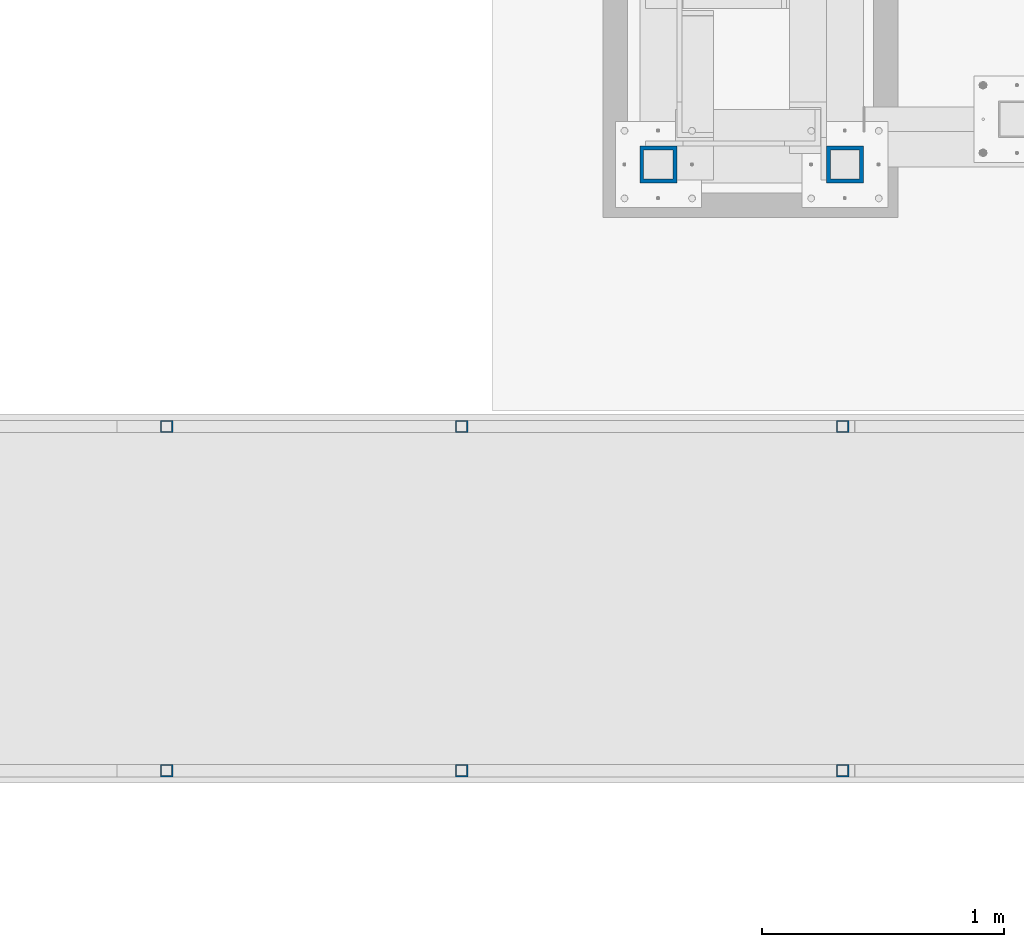
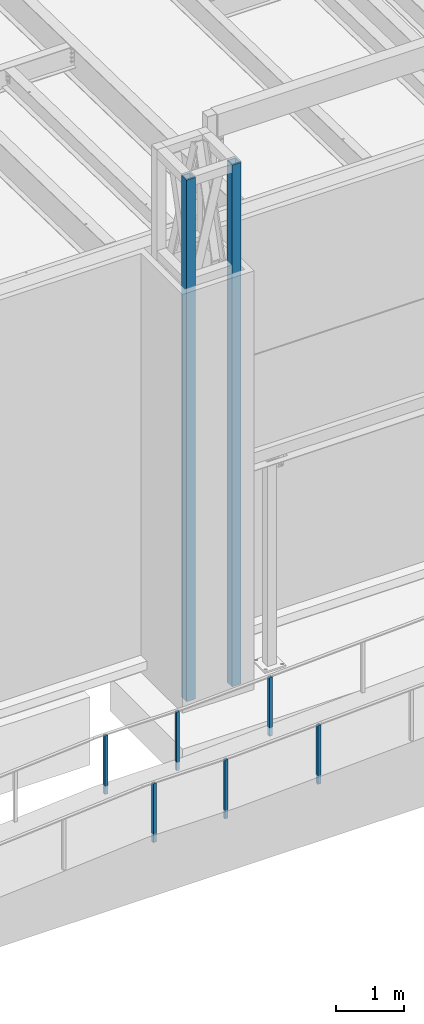
# One storey, part 878 of 1763: 8 columns, 3 elements without a shape of their own.
"""IFC2X3 building model written with IfcOpenShell, lengths in millimetres."""

from ifc_helpers import new_model, si_unit, frame, origin_with_axes, place, context, subcontext, project, spatial, faceted_brep, material, type_object, element, aggregate, save


model = new_model("IFC2X3")

# Units and contexts
model_context = context("Model", 3, precision=1e-05, world=origin_with_axes())
body_context = subcontext(model_context, "Body", "Model", "MODEL_VIEW")
ifc_project = project(units=[si_unit("LENGTHUNIT", "METRE", prefix="MILLI"), si_unit("AREAUNIT", "SQUARE_METRE"), si_unit("VOLUMEUNIT", "CUBIC_METRE"), si_unit("MASSUNIT", "GRAM", prefix="KILO"), si_unit("TIMEUNIT", "SECOND"), si_unit("PLANEANGLEUNIT", "RADIAN"), si_unit("SOLIDANGLEUNIT", "STERADIAN"), si_unit("THERMODYNAMICTEMPERATUREUNIT", "DEGREE_CELSIUS"), si_unit("LUMINOUSINTENSITYUNIT", "LUMEN")], contexts=[model_context])

# Site, building, storey
site_placement = place(None, origin_with_axes())
site = spatial("IfcSite", under=ifc_project, at=site_placement, CompositionType="ELEMENT")
building_placement = place(site_placement, origin_with_axes())
building = spatial("IfcBuilding", under=site, at=building_placement, Name="Undefined", CompositionType="ELEMENT")
storey_placement = place(building_placement, origin_with_axes())
storey = spatial("IfcBuildingStorey", under=building, at=storey_placement, Name="Undefined", CompositionType="ELEMENT", Elevation=0.0)

# Assembly, columns
assembly_1_placement = place(storey_placement, origin_with_axes())
assembly_1 = element("IfcElementAssembly", 1, at=assembly_1_placement, inside=storey, Name="FRAME", AssemblyPlace="NOTDEFINED", PredefinedType="RIGID_FRAME")
ifc_material = material()
column_type_1 = type_object("IfcColumnType", Name="HSS6X6X5/8", PredefinedType="NOTDEFINED")
column_1_placement = place(assembly_1_placement, frame((-69306.5116892775, -15452.7242675181, 5029.2), z_axis=(0.0, 1.0, 0.0), x_axis=(0.0, 0.0, 1.0)))
column_1 = element("IfcColumn", 2, at=column_1_placement, type_object=column_type_1, material=ifc_material, Name="COLUMN", ObjectType="HSS6X6X5/8", context=body_context, shape_type="Brep", body=[
    faceted_brep([(63.4999999999973, 60.3249999999971, -60.3250000000007), (63.4999999999973, -60.3249999999971, -60.3250000000007), (9429.74999873329, -60.3250000149637, -60.3250000000007), (9429.75000126672, 60.3249999850377, -60.3250000000007), (63.4999999999973, -60.3249999999971, 60.3250000000007), (9429.74999873329, -60.3250000149637, 60.3250000000007), (63.4999999999973, 60.3249999999971, 60.3250000000007), (9429.75000126672, 60.3249999850377, 60.3250000000007), (63.4999999999973, 76.1999999999971, -76.2000000000007), (63.4999999999973, 76.1999999999971, 76.2000000000007), (9429.75000000001, 76.1999999999971, 76.2000000000007), (9429.75000000001, 76.1999999999971, -76.2000000000007), (63.4999999999973, -76.1999999999971, 76.2000000000007), (9429.75000000001, -76.1999999999971, 76.2000000000007), (63.4999999999973, -76.1999999999971, -76.2000000000007), (9429.75000000001, -76.1999999999971, -76.2000000000007)], [[[0, 1, 2, 3]], [[1, 4, 5, 2]], [[4, 6, 7, 5]], [[6, 0, 3, 7]], [[8, 9, 10, 11]], [[9, 12, 13, 10]], [[12, 14, 15, 13]], [[14, 8, 11, 15]], [[13, 15, 11, 10], [5, 7, 3, 2]], [[14, 12, 9, 8], [6, 4, 1, 0]]]),
])
column_2_placement = place(assembly_1_placement, frame((-70078.03688459, -15452.7242675181, 5029.2), z_axis=(0.0, 1.0, 0.0), x_axis=(0.0, 0.0, 1.0)))
column_2 = element("IfcColumn", 3, at=column_2_placement, type_object=column_type_1, material=ifc_material, Name="FRAME", ObjectType="HSS6X6X5/8", context=body_context, shape_type="Brep", body=[
    faceted_brep([(63.4999999999973, 60.3249999999971, -60.3250000000007), (63.4999999999973, -60.3249999999971, -60.3250000000007), (9429.74999873329, -60.3250000149637, -60.3250000000007), (9429.75000126672, 60.3249999850377, -60.3250000000007), (63.4999999999973, -60.3249999999971, 60.3250000000007), (9429.74999873329, -60.3250000149637, 60.3250000000007), (63.4999999999973, 60.3249999999971, 60.3250000000007), (9429.75000126672, 60.3249999850377, 60.3250000000007), (63.4999999999973, 76.1999999999971, -76.2000000000007), (63.4999999999973, 76.1999999999971, 76.2000000000007), (9429.75000000001, 76.1999999999971, 76.2000000000007), (9429.75000000001, 76.1999999999971, -76.2000000000007), (63.4999999999973, -76.1999999999971, 76.2000000000007), (9429.75000000001, -76.1999999999971, 76.2000000000007), (63.4999999999973, -76.1999999999971, -76.2000000000007), (9429.75000000001, -76.1999999999971, -76.2000000000007)], [[[0, 1, 2, 3]], [[1, 4, 5, 2]], [[4, 6, 7, 5]], [[6, 0, 3, 7]], [[8, 9, 10, 11]], [[9, 12, 13, 10]], [[12, 14, 15, 13]], [[14, 8, 11, 15]], [[13, 15, 11, 10], [5, 7, 3, 2]], [[14, 12, 9, 8], [6, 4, 1, 0]]]),
])
aggregate(assembly_1, [column_1, column_2])

assembly_2_placement = place(storey_placement, origin_with_axes())
assembly_2 = element("IfcElementAssembly", 4, at=assembly_2_placement, inside=storey, Name="HANDRAIL", AssemblyPlace="NOTDEFINED", PredefinedType="RIGID_FRAME")
column_type_2 = type_object("IfcColumnType", Name="2X2X3/16 SQUARE TUBE SS", PredefinedType="NOTDEFINED")
column_3_placement = place(assembly_2_placement, frame((-69316.0996696563, -16535.4002326199, 4812.94154409546), z_axis=(-0.999999999891248, 0.0, 1.47479999968709e-05), x_axis=(1.47479999970212e-05, 0.0, 0.999999999891248)))
column_3 = element("IfcColumn", 5, at=column_3_placement, type_object=column_type_2, material=ifc_material, Name="POST TUBE", ObjectType="2X2X3/16 SQUARE TUBE SS", context=body_context, shape_type="Brep", body=[
    faceted_brep([(0.0, 20.6375000000007, -20.6374999999971), (0.0, -20.6375000000007, -20.6374999999971), (1058.23349084755, -20.6375000000007, -20.6375000024054), (1058.23349084755, 20.6375000000007, -20.6375000024054), (0.0, -20.6375000000007, 20.6374999999971), (1056.26220687483, -20.6375000000007, 20.6374999975815), (0.0, 20.6375000000007, 20.6374999999971), (1056.26220687483, 20.6375000000007, 20.6374999975815), (-1.45519152283669e-11, 25.4000000000015, -25.3999999999869), (1.45519152283669e-11, 25.4000000000015, 25.3999999999796), (1056.03475103182, 25.4000000000015, 25.3999999975786), (1058.46094669056, 25.4000000000015, -25.4000000024098), (0.0, -25.4000000000015, 25.3999999999942), (1056.03475103182, -25.4000000000015, 25.3999999975786), (-1.45519152283669e-11, -25.4000000000015, -25.3999999999869), (1058.46094669056, -25.4000000000015, -25.4000000024098)], [[[0, 1, 2, 3]], [[1, 4, 5, 2]], [[4, 6, 7, 5]], [[6, 0, 3, 7]], [[8, 9, 10, 11]], [[9, 12, 13, 10]], [[12, 14, 15, 13]], [[14, 8, 11, 15]], [[13, 15, 11, 10], [5, 7, 3, 2]], [[14, 12, 9, 8], [6, 4, 1, 0]]]),
])
column_4_placement = place(assembly_2_placement, frame((-72110.0219765232, -16535.4002326199, 4745.01960243319), z_axis=(-0.999999999891248, 0.0, 1.47479999968709e-05), x_axis=(1.47479999970212e-05, 0.0, 0.999999999891248)))
column_4 = element("IfcColumn", 6, at=column_4_placement, type_object=column_type_2, material=ifc_material, Name="POST TUBE", ObjectType="2X2X3/16 SQUARE TUBE SS", context=body_context, shape_type="Brep", body=[
    faceted_brep([(0.0, 20.6375000000007, -20.6374999999971), (0.0, -20.6375000000007, -20.6374999999971), (1057.27381225599, -20.6375000000007, -20.6375000025728), (1057.27381225599, 20.6375000000007, -20.6375000025728), (0.0, -20.6375000000007, 20.6374999999971), (1057.2730606794, -20.6375000000007, 20.637499997727), (0.0, 20.6375000000007, 20.6374999999971), (1057.2730606794, 20.6375000000007, 20.637499997727), (-1.45519152283669e-11, 25.4000000000015, -25.3999999999869), (1.45519152283669e-11, 25.4000000000015, 25.3999999999796), (1057.27297395903, 25.4000000000015, 25.3999999977532), (1057.27389897636, 25.4000000000015, -25.4000000025844), (0.0, -25.4000000000015, 25.3999999999942), (1057.27297395903, -25.4000000000015, 25.3999999977532), (-1.45519152283669e-11, -25.4000000000015, -25.3999999999869), (1057.27389897636, -25.4000000000015, -25.4000000025844)], [[[0, 1, 2, 3]], [[1, 4, 5, 2]], [[4, 6, 7, 5]], [[6, 0, 3, 7]], [[8, 9, 10, 11]], [[9, 12, 13, 10]], [[12, 14, 15, 13]], [[14, 8, 11, 15]], [[13, 15, 11, 10], [5, 7, 3, 2]], [[14, 12, 9, 8], [6, 4, 1, 0]]]),
])
column_5_placement = place(assembly_2_placement, frame((-70890.8222733805, -16535.4002326199, 4745.01960242799), z_axis=(-0.999999999891248, 0.0, 1.47479999968709e-05), x_axis=(1.47479999970212e-05, 0.0, 0.999999999891248)))
column_5 = element("IfcColumn", 7, at=column_5_placement, type_object=column_type_2, material=ifc_material, Name="POST TUBE", ObjectType="2X2X3/16 SQUARE TUBE SS", context=body_context, shape_type="Brep", body=[
    faceted_brep([(0.0, 20.6375000000007, -20.6374999999971), (0.0, -20.6375000000007, -20.6374999999971), (1057.27803130318, -20.6375000000007, -20.6375000025582), (1057.27803130318, 20.6375000000007, -20.6375000025582), (0.0, -20.6375000000007, 20.6374999999971), (1057.27727972659, -20.6375000000007, 20.637499997727), (0.0, 20.6375000000007, 20.6374999999971), (1057.27727972659, 20.6375000000007, 20.637499997727), (-1.45519152283669e-11, 25.4000000000015, -25.3999999999869), (1.45519152283669e-11, 25.4000000000015, 25.3999999999796), (1057.27719300622, 25.4000000000015, 25.3999999977677), (1057.27811802356, 25.4000000000015, -25.4000000025844), (0.0, -25.4000000000015, 25.3999999999942), (1057.27719300622, -25.4000000000015, 25.3999999977677), (-1.45519152283669e-11, -25.4000000000015, -25.3999999999869), (1057.27811802356, -25.4000000000015, -25.4000000025844)], [[[0, 1, 2, 3]], [[1, 4, 5, 2]], [[4, 6, 7, 5]], [[6, 0, 3, 7]], [[8, 9, 10, 11]], [[9, 12, 13, 10]], [[12, 14, 15, 13]], [[14, 8, 11, 15]], [[13, 15, 11, 10], [5, 7, 3, 2]], [[14, 12, 9, 8], [6, 4, 1, 0]]]),
])
aggregate(assembly_2, [column_3, column_4, column_5])

assembly_3_placement = place(storey_placement, origin_with_axes())
assembly_3 = element("IfcElementAssembly", 8, at=assembly_3_placement, inside=storey, Name="HANDRAIL", AssemblyPlace="NOTDEFINED", PredefinedType="RIGID_FRAME")
column_6_placement = place(assembly_3_placement, frame((-69316.0996696563, -17957.80011631, 4812.94154409546), z_axis=(-0.999999999891248, 0.0, 1.47479999968709e-05), x_axis=(1.47479999970212e-05, 0.0, 0.999999999891248)))
column_6 = element("IfcColumn", 9, at=column_6_placement, type_object=column_type_2, material=ifc_material, Name="POST TUBE", ObjectType="2X2X3/16 SQUARE TUBE SS", context=body_context, shape_type="Brep", body=[
    faceted_brep([(0.0, 20.6375000000007, -20.6374999999971), (0.0, -20.6375000000007, -20.6374999999971), (1058.23349084755, -20.6375000000007, -20.6375000024054), (1058.23349084755, 20.6375000000007, -20.6375000024054), (0.0, -20.6375000000007, 20.6374999999971), (1056.26220687483, -20.6375000000007, 20.6374999975815), (0.0, 20.6375000000007, 20.6374999999971), (1056.26220687483, 20.6375000000007, 20.6374999975815), (-1.45519152283669e-11, 25.4000000000015, -25.3999999999869), (1.45519152283669e-11, 25.4000000000015, 25.3999999999796), (1056.03475103182, 25.4000000000015, 25.3999999975786), (1058.46094669056, 25.4000000000015, -25.4000000024098), (0.0, -25.4000000000015, 25.3999999999942), (1056.03475103182, -25.4000000000015, 25.3999999975786), (-1.45519152283669e-11, -25.4000000000015, -25.3999999999869), (1058.46094669056, -25.4000000000015, -25.4000000024098)], [[[0, 1, 2, 3]], [[1, 4, 5, 2]], [[4, 6, 7, 5]], [[6, 0, 3, 7]], [[8, 9, 10, 11]], [[9, 12, 13, 10]], [[12, 14, 15, 13]], [[14, 8, 11, 15]], [[13, 15, 11, 10], [5, 7, 3, 2]], [[14, 12, 9, 8], [6, 4, 1, 0]]]),
])
column_7_placement = place(assembly_3_placement, frame((-72110.0219765232, -17957.80011631, 4745.01960243319), z_axis=(-0.999999999891248, 0.0, 1.47479999968709e-05), x_axis=(1.47479999970212e-05, 0.0, 0.999999999891248)))
column_7 = element("IfcColumn", 10, at=column_7_placement, type_object=column_type_2, material=ifc_material, Name="POST TUBE", ObjectType="2X2X3/16 SQUARE TUBE SS", context=body_context, shape_type="Brep", body=[
    faceted_brep([(0.0, 20.6375000000007, -20.6374999999971), (0.0, -20.6375000000007, -20.6374999999971), (1057.27381225599, -20.6375000000007, -20.6375000025728), (1057.27381225599, 20.6375000000007, -20.6375000025728), (0.0, -20.6375000000007, 20.6374999999971), (1057.2730606794, -20.6375000000007, 20.637499997727), (0.0, 20.6375000000007, 20.6374999999971), (1057.2730606794, 20.6375000000007, 20.637499997727), (-1.45519152283669e-11, 25.4000000000015, -25.3999999999869), (1.45519152283669e-11, 25.4000000000015, 25.3999999999796), (1057.27297395903, 25.4000000000015, 25.3999999977532), (1057.27389897636, 25.4000000000015, -25.4000000025844), (0.0, -25.4000000000015, 25.3999999999942), (1057.27297395903, -25.4000000000015, 25.3999999977532), (-1.45519152283669e-11, -25.4000000000015, -25.3999999999869), (1057.27389897636, -25.4000000000015, -25.4000000025844)], [[[0, 1, 2, 3]], [[1, 4, 5, 2]], [[4, 6, 7, 5]], [[6, 0, 3, 7]], [[8, 9, 10, 11]], [[9, 12, 13, 10]], [[12, 14, 15, 13]], [[14, 8, 11, 15]], [[13, 15, 11, 10], [5, 7, 3, 2]], [[14, 12, 9, 8], [6, 4, 1, 0]]]),
])
column_8_placement = place(assembly_3_placement, frame((-70890.8222733805, -17957.80011631, 4745.01960242799), z_axis=(-0.999999999891248, 0.0, 1.47479999968709e-05), x_axis=(1.47479999970212e-05, 0.0, 0.999999999891248)))
column_8 = element("IfcColumn", 11, at=column_8_placement, type_object=column_type_2, material=ifc_material, Name="POST TUBE", ObjectType="2X2X3/16 SQUARE TUBE SS", context=body_context, shape_type="Brep", body=[
    faceted_brep([(0.0, 20.6375000000007, -20.6374999999971), (0.0, -20.6375000000007, -20.6374999999971), (1057.27803130318, -20.6375000000007, -20.6375000025582), (1057.27803130318, 20.6375000000007, -20.6375000025582), (0.0, -20.6375000000007, 20.6374999999971), (1057.27727972659, -20.6375000000007, 20.637499997727), (0.0, 20.6375000000007, 20.6374999999971), (1057.27727972659, 20.6375000000007, 20.637499997727), (-1.45519152283669e-11, 25.4000000000015, -25.3999999999869), (1.45519152283669e-11, 25.4000000000015, 25.3999999999796), (1057.27719300622, 25.4000000000015, 25.3999999977677), (1057.27811802356, 25.4000000000015, -25.4000000025844), (0.0, -25.4000000000015, 25.3999999999942), (1057.27719300622, -25.4000000000015, 25.3999999977677), (-1.45519152283669e-11, -25.4000000000015, -25.3999999999869), (1057.27811802356, -25.4000000000015, -25.4000000025844)], [[[0, 1, 2, 3]], [[1, 4, 5, 2]], [[4, 6, 7, 5]], [[6, 0, 3, 7]], [[8, 9, 10, 11]], [[9, 12, 13, 10]], [[12, 14, 15, 13]], [[14, 8, 11, 15]], [[13, 15, 11, 10], [5, 7, 3, 2]], [[14, 12, 9, 8], [6, 4, 1, 0]]]),
])
aggregate(assembly_3, [column_6, column_7, column_8])

save(model, "model.ifc")
